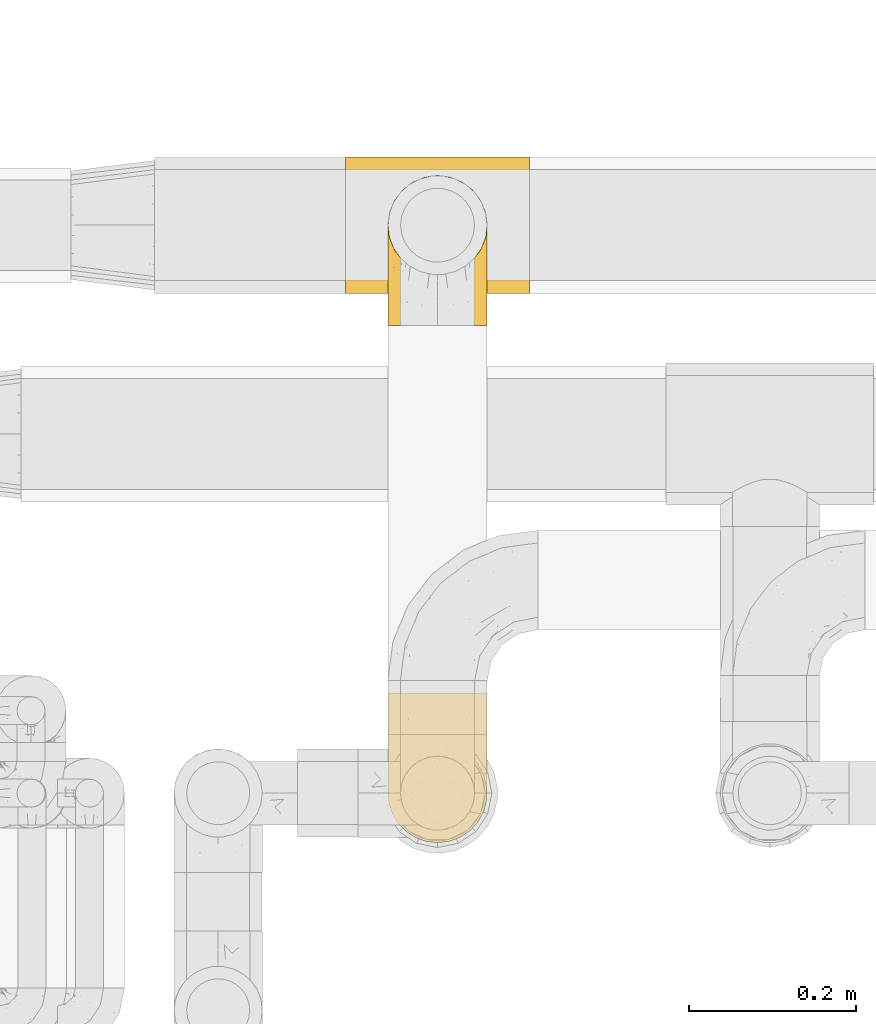
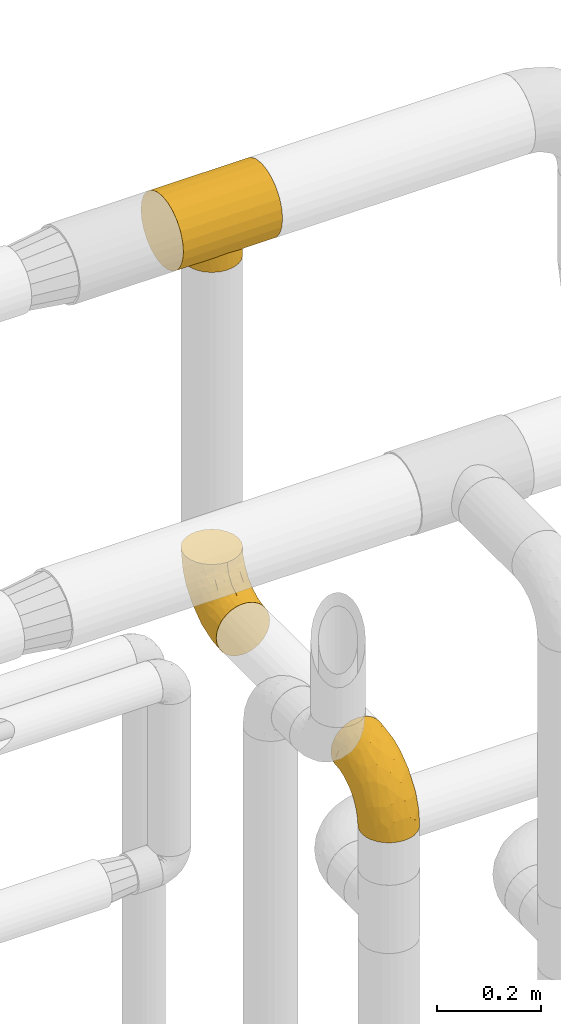
# One storey, part 461 of 827: 3 coverings.
"""IFC2X3 building model written with IfcOpenShell, lengths in millimetres."""

import ifcopenshell
import ifcopenshell.guid

model = None  # the IFC model being written
_history = None  # IfcOwnerHistory: only IFC2X3 demands one
_inside = {}  # id of a spatial element -> (the spatial element, [elements in it])
_under = {}  # id of a project, library or spatial element -> (it, [spatial elements below it])
_declared = {}  # id of a project -> (the project, [libraries it declares])
_typed = {}  # id of a type object -> (the type object, [elements of that type])
_made_of = {}  # id of a material, layer set ... -> (it, [elements and type objects made of it])


def new_model(schema):
    """Start an empty IFC model of exactly this schema.

    Asked for "IFC4X3", IfcOpenShell would pick the latest addendum, in which some entities
    have other attributes; the version numbers below select the first issue.
    IFC2X3 requires an IfcOwnerHistory on every rooted entity: one is made here for all.
    """
    global model, _history
    if schema == "IFC4X3":
        model = ifcopenshell.file(schema_version=(4, 3, 0, 0))
    else:
        model = ifcopenshell.file(schema=schema)
    _inside.clear()
    _under.clear()
    _declared.clear()
    _typed.clear()
    _made_of.clear()
    _history = None
    if model.schema == "IFC2X3":
        org = make("IfcOrganization", Name="unknown")
        user = make(
            "IfcPersonAndOrganization",
            ThePerson=make("IfcPerson", FamilyName="unknown"),
            TheOrganization=org,
        )
        app = make(
            "IfcApplication",
            ApplicationDeveloper=org,
            Version="unknown",
            ApplicationFullName="unknown",
            ApplicationIdentifier="unknown",
        )
        _history = make(
            "IfcOwnerHistory",
            OwningUser=user,
            OwningApplication=app,
            ChangeAction="ADDED",
            CreationDate=0,
        )
    return model


def make(cls, **values):
    """One entity of the class cls with the attributes given. An attribute that is None is left unset."""
    return model.create_entity(
        cls, **{name: value for name, value in values.items() if value is not None}
    )


def entity(cls, *values):
    """Any entity or typed value of the class cls, its attributes in the order of the schema. None: left unset."""
    e = model.create_entity(cls)
    for i, value in enumerate(values):
        if value is not None:
            e[i] = value
    return e


def rooted(cls, **values):
    """An entity with a GlobalId (a new one), such as an element, a storey or a relation."""
    return make(cls, GlobalId=ifcopenshell.guid.new(), OwnerHistory=_history, **values)


def si_unit(unit_type, name, prefix=None):
    """IfcSIUnit, for example si_unit("LENGTHUNIT", "METRE", prefix="MILLI")."""
    return make("IfcSIUnit", UnitType=unit_type, Prefix=prefix, Name=name)


def converted_unit(unit_type, name, factor, base, dimensions=None, offset=None):
    """IfcConversionBasedUnit, such as the inch: factor (a typed value) times the base unit."""
    return make(
        "IfcConversionBasedUnit"
        if offset is None
        else "IfcConversionBasedUnitWithOffset",
        ConversionOffset=offset,
        Dimensions=None
        if dimensions is None
        else entity("IfcDimensionalExponents", *dimensions),
        UnitType=unit_type,
        Name=name,
        ConversionFactor=make(
            "IfcMeasureWithUnit", ValueComponent=factor, UnitComponent=base
        ),
    )


def derived_unit(unit_type, elements):
    """IfcDerivedUnit: a product of units, each with its exponent."""
    return make(
        "IfcDerivedUnit",
        Elements=[
            make("IfcDerivedUnitElement", Unit=unit, Exponent=power)
            for unit, power in elements
        ],
        UnitType=unit_type,
    )


def assignment(units):
    """IfcUnitAssignment: the units of a project."""
    return None if units is None else make("IfcUnitAssignment", Units=units)


def point(xyz):
    """IfcCartesianPoint."""
    return None if xyz is None else make("IfcCartesianPoint", Coordinates=xyz)


def direction(xyz):
    """IfcDirection."""
    return None if xyz is None else make("IfcDirection", DirectionRatios=xyz)


def frame(location, z_axis=None, x_axis=None):
    """IfcAxis2Placement3D, a coordinate frame: its origin and axes. An axis left out is left unset."""
    return make(
        "IfcAxis2Placement3D",
        Location=point(location),
        Axis=direction(z_axis),
        RefDirection=direction(x_axis),
    )


def origin():
    """The frame at (0, 0, 0) with its axes left unset."""
    return frame((0.0, 0.0, 0.0))


def place(relative_to, where):
    """IfcLocalPlacement: puts the frame where relative to a parent placement (None: the world)."""
    return make(
        "IfcLocalPlacement", PlacementRelTo=relative_to, RelativePlacement=where
    )


def context(
    kind, dimensions, precision=None, world=None, true_north=None, identifier=None
):
    """IfcGeometricRepresentationContext, for example the 3D "Model" context."""
    return make(
        "IfcGeometricRepresentationContext",
        ContextIdentifier=identifier,
        ContextType=kind,
        CoordinateSpaceDimension=dimensions,
        Precision=precision,
        WorldCoordinateSystem=world,
        TrueNorth=true_north,
    )


def subcontext(parent, identifier, kind, view, scale=None):
    """IfcGeometricRepresentationSubContext, for example "Body" below "Model"."""
    return make(
        "IfcGeometricRepresentationSubContext",
        ContextIdentifier=identifier,
        ContextType=kind,
        ParentContext=parent,
        TargetScale=scale,
        TargetView=view,
    )


def project(units=None, contexts=None):
    """IfcProject with its units and contexts."""
    return rooted(
        "IfcProject",
        Name="project",
        RepresentationContexts=contexts,
        UnitsInContext=assignment(units),
    )


def spatial(cls, under=None, at=None, **own):
    """A site, building, storey or space (cls), placed at a placement, below another one or the project."""
    s = rooted(cls, ObjectPlacement=at, **own)
    if under is not None:
        _under.setdefault(under.id(), (under, []))[1].append(s)
    return s


def faces_of(points, faces, orient=None, outer=None):
    """IfcFace entities. A face is a list of loops; a loop is a list of indices into points, from 0.

    orient and outer hold one flag for each loop. By default every Orientation is true, the
    first loop of a face is its IfcFaceOuterBound and the others are IfcFaceBound.
    """
    made = []
    for i, loops in enumerate(faces):
        bounds = []
        for j, loop in enumerate(loops):
            is_outer = j == 0 if outer is None else outer[i][j]
            bounds.append(
                make(
                    "IfcFaceOuterBound" if is_outer else "IfcFaceBound",
                    Bound=make("IfcPolyLoop", Polygon=[points[k] for k in loop]),
                    Orientation=True if orient is None else orient[i][j],
                )
            )
        made.append(make("IfcFace", Bounds=bounds))
    return made


def faceted_brep(points, faces, orient=None, outer=None, voids=None):
    """IfcFacetedBrep: a solid bounded by flat faces; with voids (closed shells), ...WithVoids."""
    shared = [point(p) for p in points]
    hull = make("IfcClosedShell", CfsFaces=faces_of(shared, faces, orient, outer))
    if voids is None:
        return make("IfcFacetedBrep", Outer=hull)
    return make(
        "IfcFacetedBrepWithVoids",
        Outer=hull,
        Voids=[
            make(cls, CfsFaces=faces_of(shared, fs, o, b)) for cls, fs, o, b in voids
        ],
    )


def shape(context_of_items, identifier, shape_type, items):
    """IfcShapeRepresentation: the items that make up one representation, for example the "Body"."""
    return make(
        "IfcShapeRepresentation",
        ContextOfItems=context_of_items,
        RepresentationIdentifier=identifier,
        RepresentationType=shape_type,
        Items=items,
    )


def made_of(thing, what):
    """Note that an element or type object is made of a material, layer set ...; save() writes the relation."""
    if what is not None:
        _made_of.setdefault(what.id(), (what, []))[1].append(thing)
    return thing


def element(
    cls,
    number,
    at=None,
    inside=None,
    cuts=None,
    type_object=None,
    material=None,
    context=None,
    identifier="Body",
    shape_type=None,
    held_by="IfcProductDefinitionShape",
    body=None,
    shapes=None,
    **own,
):
    """One element of the class cls, such as IfcWall. Its Tag is "e" and its number.

    at: its placement. inside: the storey or other place that contains it. cuts: it is an
    opening in that element (IfcRelVoidsElement). A single representation is given by context,
    identifier, shape_type and body (its items); several are given by shapes. held_by: the class
    of the entity that holds the representations. save() writes the other relations.
    """
    e = rooted(cls, Tag="e%d" % number, ObjectPlacement=at, **own)
    if body is not None:
        shapes = [shape(context, identifier, shape_type, body)]
    if shapes is not None:
        e.Representation = make(held_by, Representations=shapes)
    if inside is not None:
        _inside.setdefault(inside.id(), (inside, []))[1].append(e)
    if cuts is not None:
        rooted(
            "IfcRelVoidsElement", RelatingBuildingElement=cuts, RelatedOpeningElement=e
        )
    if type_object is not None:
        _typed.setdefault(type_object.id(), (type_object, []))[1].append(e)
    return made_of(e, material)


def aggregate(whole, parts):
    """IfcRelAggregates: a whole, such as a stair, and the parts it consists of."""
    return rooted("IfcRelAggregates", RelatingObject=whole, RelatedObjects=parts)


def save(model, path):
    """Write the relations noted so far, then the file.

    IfcRelAggregates (storeys below a building ...), IfcRelContainedInSpatialStructure (elements
    in a storey), IfcRelDefinesByType, IfcRelAssociatesMaterial and IfcRelDeclares: one each for
    every whole, place, type object, material and project.
    """
    for whole, parts in _under.values():
        aggregate(whole, parts)
    for where, things in _inside.values():
        rooted(
            "IfcRelContainedInSpatialStructure",
            RelatedElements=things,
            RelatingStructure=where,
        )
    for kind, things in _typed.values():
        rooted("IfcRelDefinesByType", RelatedObjects=things, RelatingType=kind)
    for what, things in _made_of.values():
        rooted("IfcRelAssociatesMaterial", RelatedObjects=things, RelatingMaterial=what)
    for by, libraries in _declared.values():
        rooted("IfcRelDeclares", RelatingContext=by, RelatedDefinitions=libraries)
    model.write(path)


model = new_model("IFC2X3")

# Units and contexts
model_context = context("Model", 3, precision=0.01, world=origin(), true_north=direction((6.12303176911189e-17, 1.0)))
body_context = subcontext(model_context, "Body", "Model", "MODEL_VIEW")
ifc_project = project(units=[si_unit("LENGTHUNIT", "METRE", prefix="MILLI"), si_unit("AREAUNIT", "SQUARE_METRE"), si_unit("VOLUMEUNIT", "CUBIC_METRE"), converted_unit("PLANEANGLEUNIT", "DEGREE", entity("IfcRatioMeasure", 0.0174532925199433), si_unit("PLANEANGLEUNIT", "RADIAN"), dimensions=[0, 0, 0, 0, 0, 0, 0]), si_unit("MASSUNIT", "GRAM", prefix="KILO"), derived_unit("MASSDENSITYUNIT", [(si_unit("MASSUNIT", "GRAM", prefix="KILO"), 1), (si_unit("LENGTHUNIT", "METRE"), -3)]), derived_unit("MOMENTOFINERTIAUNIT", [(si_unit("LENGTHUNIT", "METRE"), 4)]), si_unit("TIMEUNIT", "SECOND"), si_unit("FREQUENCYUNIT", "HERTZ"), si_unit("THERMODYNAMICTEMPERATUREUNIT", "DEGREE_CELSIUS"), derived_unit("THERMALTRANSMITTANCEUNIT", [(si_unit("MASSUNIT", "GRAM", prefix="KILO"), 1), (si_unit("THERMODYNAMICTEMPERATUREUNIT", "KELVIN"), -1), (si_unit("TIMEUNIT", "SECOND"), -3)]), derived_unit("VOLUMETRICFLOWRATEUNIT", [(si_unit("LENGTHUNIT", "METRE"), 3), (si_unit("TIMEUNIT", "SECOND"), -1)]), derived_unit("MASSFLOWRATEUNIT", [(si_unit("MASSUNIT", "GRAM", prefix="KILO"), 1), (si_unit("TIMEUNIT", "SECOND"), -1)]), derived_unit("ROTATIONALFREQUENCYUNIT", [(si_unit("TIMEUNIT", "SECOND"), -1)]), si_unit("ELECTRICCURRENTUNIT", "AMPERE"), si_unit("ELECTRICVOLTAGEUNIT", "VOLT"), si_unit("POWERUNIT", "WATT"), si_unit("FORCEUNIT", "NEWTON", prefix="KILO"), si_unit("ILLUMINANCEUNIT", "LUX"), si_unit("LUMINOUSFLUXUNIT", "LUMEN"), si_unit("LUMINOUSINTENSITYUNIT", "CANDELA"), derived_unit("USERDEFINED", [(si_unit("MASSUNIT", "GRAM", prefix="KILO"), -1), (si_unit("LENGTHUNIT", "METRE"), -2), (si_unit("TIMEUNIT", "SECOND"), 3), (si_unit("LUMINOUSFLUXUNIT", "LUMEN"), 1)]), derived_unit("LINEARVELOCITYUNIT", [(si_unit("LENGTHUNIT", "METRE"), 1), (si_unit("TIMEUNIT", "SECOND"), -1)]), si_unit("PRESSUREUNIT", "PASCAL"), derived_unit("USERDEFINED", [(si_unit("LENGTHUNIT", "METRE"), -2), (si_unit("MASSUNIT", "GRAM", prefix="KILO"), 1), (si_unit("TIMEUNIT", "SECOND"), -2)]), derived_unit("LINEARFORCEUNIT", [(si_unit("MASSUNIT", "GRAM", prefix="KILO"), 1), (si_unit("LENGTHUNIT", "METRE"), 1), (si_unit("TIMEUNIT", "SECOND"), -2), (si_unit("LENGTHUNIT", "METRE"), -1)]), derived_unit("PLANARFORCEUNIT", [(si_unit("MASSUNIT", "GRAM", prefix="KILO"), 1), (si_unit("LENGTHUNIT", "METRE"), 1), (si_unit("TIMEUNIT", "SECOND"), -2), (si_unit("LENGTHUNIT", "METRE"), -2)])], contexts=[model_context])

# Site, building, storey
site_placement = place(None, origin())
site = spatial("IfcSite", under=ifc_project, at=site_placement, CompositionType="ELEMENT")
building_placement = place(site_placement, origin())
building = spatial("IfcBuilding", under=site, at=building_placement, CompositionType="ELEMENT")
storey_placement = place(building_placement, frame((0.0, 0.0, 28200.0)))
storey = spatial("IfcBuildingStorey", under=building, at=storey_placement, Name="08", CompositionType="ELEMENT", Elevation=28200.0)

# Coverings
covering_1_placement = place(storey_placement, frame((56940.07, 18097.0, 3404.74)))
element("IfcCovering", 1, at=covering_1_placement, inside=storey, Name=":ADSK_", ObjectType=":ADSK_", PredefinedType="INSULATION", context=body_context, shape_type="Brep", body=[
    faceted_brep([(220.0, 123.85, 165.58), (220.0, 104.19, 173.72), (220.0, 83.1, 176.5), (220.0, 62.0, 173.72), (220.0, 42.35, 165.58), (220.0, 25.47, 152.63), (220.0, 12.51, 135.75), (220.0, 4.37, 116.09), (220.0, 1.6, 95.0), (220.0, 4.37, 73.91), (220.0, 12.51, 54.25), (220.0, 25.47, 37.37), (220.0, 33.91, 30.89), (220.0, 42.35, 24.42), (220.0, 52.17, 20.35), (220.0, 62.0, 16.28), (220.0, 72.55, 14.89), (220.0, 83.1, 13.5), (220.0, 93.64, 14.89), (220.0, 104.19, 16.28), (220.0, 114.02, 20.35), (220.0, 123.85, 24.42), (220.0, 132.28, 30.89), (220.0, 140.72, 37.37), (220.0, 153.68, 54.25), (220.0, 161.82, 73.91), (220.0, 164.6, 95.0), (220.0, 161.82, 116.09), (220.0, 153.68, 135.75), (220.0, 140.72, 152.63), (0.0, 1.6, 95.0), (0.0, 4.37, 116.09), (0.0, 12.51, 135.75), (0.0, 25.47, 152.63), (0.0, 42.35, 165.58), (0.0, 62.0, 173.72), (0.0, 83.1, 176.5), (0.0, 104.19, 173.72), (0.0, 123.85, 165.58), (0.0, 140.72, 152.63), (0.0, 153.68, 135.75), (0.0, 161.82, 116.09), (0.0, 164.6, 95.0), (0.0, 161.82, 73.91), (0.0, 153.68, 54.25), (0.0, 140.72, 37.37), (0.0, 132.28, 30.89), (0.0, 123.85, 24.42), (0.0, 114.02, 20.35), (0.0, 104.19, 16.28), (0.0, 93.64, 14.89), (0.0, 83.1, 13.5), (0.0, 72.55, 14.89), (0.0, 62.0, 16.28), (0.0, 52.17, 20.35), (0.0, 42.35, 24.42), (0.0, 33.91, 30.89), (0.0, 25.47, 37.37), (0.0, 12.51, 54.25), (0.0, 4.37, 73.91), (86.77, 28.32, 34.66), (68.15, 40.8, 25.33), (164.68, 59.63, 16.95), (159.1, 49.48, 20.75), (97.96, 24.83, 38.02), (76.81, 33.71, 30.16), (110.0, 23.6, 39.3), (122.04, 24.83, 38.02), (133.23, 28.32, 34.66), (169.5, 83.1, 13.5), (168.26, 71.0, 14.4), (143.19, 33.71, 30.16), (151.85, 40.8, 25.33), (60.9, 49.48, 20.75), (51.74, 71.0, 14.4), (55.32, 59.63, 16.95), (50.5, 83.1, 13.5), (51.74, 95.19, 14.4), (60.9, 116.71, 20.75), (55.32, 106.56, 16.95), (68.15, 125.39, 25.33), (168.26, 95.19, 14.4), (164.68, 106.56, 16.95), (159.1, 116.71, 20.75), (151.85, 125.39, 25.33), (86.77, 137.88, 34.66), (76.81, 132.48, 30.16), (97.96, 141.36, 38.02), (110.0, 142.6, 39.3), (133.23, 137.88, 34.66), (143.19, 132.48, 30.16), (122.04, 141.36, 38.02), (94.6, 25.62, 0.0), (80.25, 31.57, 0.0), (67.93, 41.02, 0.0), (58.47, 53.35, 0.0), (52.53, 67.7, 0.0), (50.5, 83.1, 0.0), (52.53, 98.5, 0.0), (58.47, 112.85, 0.0), (67.93, 125.17, 0.0), (80.25, 134.62, 0.0), (94.6, 140.57, 0.0), (110.0, 142.6, 0.0), (125.4, 140.57, 0.0), (139.75, 134.62, 0.0), (152.07, 125.17, 0.0), (161.53, 112.85, 0.0), (167.47, 98.5, 0.0), (169.5, 83.1, 0.0), (167.47, 67.7, 0.0), (161.53, 53.35, 0.0), (152.07, 41.02, 0.0), (139.75, 31.57, 0.0), (125.4, 25.62, 0.0), (110.0, 23.6, 0.0)], [[[0, 1, 2, 3, 4, 5, 6, 7, 8, 9, 10, 11, 12, 13, 14, 15, 16, 17, 18, 19, 20, 21, 22, 23, 24, 25, 26, 27, 28, 29]], [[30, 31, 32, 33, 34, 35, 36, 37, 38, 39, 40, 41, 42, 43, 44, 45, 46, 47, 48, 49, 50, 51, 52, 53, 54, 55, 56, 57, 58, 59]], [[34, 33, 5, 4]], [[2, 36, 35, 3]], [[3, 35, 34, 4]], [[6, 32, 31, 7]], [[7, 31, 30, 8]], [[5, 33, 32, 6]], [[59, 9, 8, 30]], [[58, 10, 9, 59]], [[56, 60, 57]], [[56, 55, 61]], [[62, 14, 63]], [[60, 64, 57]], [[60, 56, 65]], [[58, 57, 66]], [[57, 64, 66]], [[58, 66, 10]], [[66, 11, 10]], [[67, 68, 11]], [[69, 16, 70]], [[68, 12, 11]], [[12, 68, 71]], [[72, 12, 71]], [[67, 11, 66]], [[73, 55, 54]], [[74, 53, 52]], [[54, 75, 73]], [[75, 54, 53]], [[73, 61, 55]], [[61, 65, 56]], [[51, 76, 52]], [[69, 17, 16]], [[74, 52, 76]], [[53, 74, 75]], [[72, 63, 13]], [[14, 62, 15]], [[63, 14, 13]], [[13, 12, 72]], [[16, 15, 70]], [[70, 15, 62]], [[51, 50, 76]], [[17, 69, 18]], [[77, 50, 49]], [[48, 47, 78]], [[79, 49, 48]], [[47, 80, 78]], [[49, 79, 77]], [[81, 18, 69]], [[81, 82, 19]], [[21, 83, 84]], [[20, 82, 83]], [[82, 20, 19]], [[46, 80, 47]], [[46, 85, 86]], [[85, 46, 45]], [[79, 48, 78]], [[87, 85, 45]], [[45, 88, 87]], [[81, 19, 18]], [[24, 44, 43, 25]], [[24, 88, 44]], [[44, 88, 45]], [[43, 42, 26, 25]], [[89, 22, 90]], [[89, 23, 22]], [[76, 50, 77]], [[22, 84, 90]], [[84, 22, 21]], [[89, 91, 23]], [[80, 46, 86]], [[88, 23, 91]], [[88, 24, 23]], [[83, 21, 20]], [[27, 41, 40, 28]], [[28, 40, 39, 29]], [[42, 41, 27, 26]], [[0, 38, 37, 1]], [[1, 37, 36, 2]], [[29, 39, 38, 0]], [[92, 93, 94, 95, 96, 97, 98, 99, 100, 101, 102, 103, 104, 105, 106, 107, 108, 109, 110, 111, 112, 113, 114, 115]], [[74, 97, 96]], [[96, 95, 75]], [[94, 73, 95]], [[74, 76, 97]], [[73, 75, 95]], [[74, 96, 75]], [[94, 61, 73]], [[61, 94, 65]], [[65, 94, 93]], [[60, 93, 92]], [[64, 92, 115]], [[65, 93, 60]], [[64, 60, 92]], [[66, 64, 115]], [[67, 115, 114]], [[114, 113, 68]], [[112, 71, 113]], [[112, 72, 71]], [[66, 115, 67]], [[67, 114, 68]], [[113, 71, 68]], [[63, 112, 111]], [[110, 109, 70]], [[62, 111, 110]], [[62, 63, 111]], [[69, 70, 109]], [[62, 110, 70]], [[112, 63, 72]], [[81, 109, 108]], [[108, 107, 82]], [[106, 83, 107]], [[81, 69, 109]], [[83, 82, 107]], [[81, 108, 82]], [[106, 84, 83]], [[84, 106, 90]], [[90, 106, 105]], [[89, 105, 104]], [[91, 104, 103]], [[90, 105, 89]], [[91, 89, 104]], [[88, 91, 103]], [[87, 103, 102]], [[102, 101, 85]], [[100, 86, 101]], [[100, 80, 86]], [[88, 103, 87]], [[87, 102, 85]], [[101, 86, 85]], [[78, 100, 99]], [[99, 98, 79]], [[97, 77, 98]], [[79, 78, 99]], [[76, 77, 97]], [[79, 98, 77]], [[100, 78, 80]]]),
])
covering_2_placement = place(storey_placement, frame((56988.97, 18058.5, 2538.65)))
element("IfcCovering", 2, at=covering_2_placement, inside=storey, Name=":ADSK_", ObjectType=":ADSK_", PredefinedType="INSULATION", context=body_context, shape_type="Brep", body=[
    faceted_brep([(3.09, 1.6, 47.85), (7.49, 1.6, 35.28), (14.58, 1.6, 23.99), (24.0, 1.6, 14.57), (35.29, 1.6, 7.48), (47.87, 1.6, 3.08), (61.1, 1.6, 1.6), (74.34, 1.6, 3.09), (86.92, 1.6, 7.49), (98.2, 1.6, 14.58), (107.62, 1.6, 24.0), (114.71, 1.6, 35.29), (119.11, 1.6, 47.87), (120.6, 1.6, 61.1), (119.1, 1.6, 74.34), (114.7, 1.6, 86.92), (107.61, 1.6, 98.2), (98.19, 1.6, 107.62), (86.9, 1.6, 114.71), (74.32, 1.6, 119.11), (61.1, 1.6, 120.6), (47.85, 1.6, 119.1), (35.28, 1.6, 114.7), (23.99, 1.6, 107.61), (14.57, 1.6, 98.19), (7.48, 1.6, 86.9), (3.08, 1.6, 74.32), (1.6, 1.6, 61.1), (76.5, 64.12, 181.1), (90.85, 70.07, 181.1), (103.17, 79.52, 181.1), (112.62, 91.85, 181.1), (118.57, 106.2, 181.1), (120.6, 121.6, 181.1), (118.57, 137.0, 181.1), (112.62, 151.35, 181.1), (103.17, 163.67, 181.1), (90.85, 173.12, 181.1), (76.5, 179.07, 181.1), (61.1, 181.1, 181.1), (45.7, 179.07, 181.1), (31.35, 173.12, 181.1), (19.02, 163.67, 181.1), (9.57, 151.35, 181.1), (3.62, 137.0, 181.1), (1.6, 121.6, 181.1), (3.62, 106.2, 181.1), (9.57, 91.85, 181.1), (19.02, 79.52, 181.1), (31.35, 70.07, 181.1), (45.7, 64.12, 181.1), (61.1, 62.1, 181.1), (26.31, 166.85, 149.36), (39.89, 171.8, 137.95), (28.09, 156.7, 112.73), (50.3, 175.89, 142.53), (61.1, 174.98, 134.64), (12.16, 34.39, 30.78), (42.08, 141.86, 74.16), (61.1, 157.05, 91.35), (61.1, 128.52, 54.17), (6.43, 125.77, 109.16), (9.16, 142.49, 132.51), (15.36, 137.62, 100.6), (4.19, 133.72, 143.49), (2.63, 116.57, 118.25), (30.97, 116.34, 53.89), (24.52, 137.54, 84.22), (39.03, 160.1, 106.32), (50.35, 166.8, 113.45), (15.92, 154.26, 137.68), (61.1, 48.05, 7.71), (42.9, 44.99, 9.86), (32.76, 75.77, 25.56), (45.82, 109.34, 40.03), (48.35, 78.35, 20.36), (3.49, 96.98, 85.71), (9.05, 106.86, 75.88), (7.36, 67.36, 51.26), (3.1, 49.85, 56.83), (1.6, 72.13, 84.01), (1.6, 98.68, 110.56), (1.6, 107.2, 127.29), (1.6, 115.72, 144.01), (61.1, 91.35, 25.64), (21.1, 45.24, 22.95), (15.48, 73.45, 40.15), (30.83, 33.95, 12.95), (6.04, 32.97, 42.03), (1.6, 16.23, 63.41), (1.6, 38.68, 66.97), (23.42, 74.48, 31.89), (1.6, 85.4, 97.29), (17.92, 115.39, 67.3), (1.6, 55.4, 75.49), (1.6, 119.28, 166.46), (7.93, 85.98, 141.36), (8.89, 71.16, 121.72), (16.11, 70.35, 138.16), (3.9, 103.0, 159.88), (3.02, 94.6, 128.08), (19.8, 55.86, 126.23), (3.12, 81.81, 110.87), (47.53, 60.95, 162.96), (50.13, 52.54, 146.61), (61.1, 57.49, 157.94), (15.01, 24.83, 102.08), (19.01, 37.73, 112.03), (10.55, 50.74, 107.36), (10.96, 87.65, 162.91), (20.75, 74.24, 157.88), (39.41, 15.74, 118.07), (26.2, 20.12, 111.72), (33.73, 61.93, 151.58), (36.85, 65.86, 167.61), (46.97, 40.95, 132.93), (61.1, 44.38, 138.32), (5.84, 38.05, 90.2), (2.73, 55.63, 87.09), (5.41, 56.15, 98.46), (37.06, 31.75, 122.87), (32.67, 49.11, 132.83), (3.19, 20.72, 76.52), (27.56, 32.8, 117.49), (8.27, 18.32, 90.0), (48.52, 24.08, 123.48), (61.1, 24.75, 125.2), (2.79, 70.12, 97.44), (24.84, 61.67, 139.94), (2.63, 41.55, 79.72), (4.47, 96.92, 145.56), (13.37, 81.07, 152.47), (106.07, 70.33, 138.17), (102.38, 55.85, 126.24), (113.29, 71.15, 121.74), (95.98, 20.12, 111.73), (107.17, 24.84, 102.09), (97.33, 61.65, 139.94), (116.35, 38.08, 90.22), (119.56, 41.53, 79.72), (119.46, 55.63, 87.08), (75.21, 40.93, 132.91), (74.65, 60.95, 162.97), (85.34, 65.86, 167.61), (111.23, 87.65, 162.91), (108.82, 81.07, 152.47), (114.26, 85.98, 141.36), (119.17, 94.6, 128.08), (119.3, 84.2, 112.07), (120.6, 98.68, 110.56), (118.29, 103.0, 159.88), (120.6, 119.28, 166.46), (95.24, 40.95, 121.68), (85.12, 31.73, 122.86), (101.44, 74.24, 157.88), (111.63, 50.74, 107.38), (72.08, 52.54, 146.61), (103.17, 37.73, 112.05), (73.66, 24.06, 123.48), (118.38, 68.67, 101.72), (113.92, 18.33, 90.01), (117.72, 96.92, 145.56), (82.77, 15.72, 118.07), (119.0, 20.72, 76.53), (89.51, 49.08, 132.81), (120.6, 38.68, 66.97), (120.6, 16.23, 63.41), (120.6, 55.4, 75.49), (116.32, 51.76, 97.07), (120.6, 85.4, 97.29), (120.6, 115.72, 144.01), (120.6, 107.2, 127.29), (120.6, 72.13, 84.01), (88.46, 61.93, 151.59), (94.1, 156.7, 112.73), (95.88, 166.85, 149.36), (106.27, 154.26, 137.68), (113.03, 142.49, 132.51), (71.89, 175.89, 142.53), (82.3, 171.8, 137.95), (71.84, 166.8, 113.45), (119.56, 116.57, 118.25), (106.83, 137.62, 100.6), (76.37, 109.34, 40.03), (91.22, 116.34, 53.89), (89.44, 75.76, 25.56), (118.7, 96.98, 85.71), (118.0, 133.72, 143.49), (83.16, 160.1, 106.32), (77.34, 78.71, 21.51), (79.3, 44.98, 9.86), (80.11, 141.86, 74.16), (116.16, 32.97, 42.04), (119.09, 49.86, 56.84), (115.76, 125.77, 109.16), (113.14, 106.86, 75.88), (110.04, 34.39, 30.8), (101.1, 45.23, 22.96), (97.67, 137.54, 84.22), (91.37, 33.95, 12.96), (114.84, 67.37, 51.28), (106.72, 73.45, 40.16), (104.27, 115.39, 67.3), (98.78, 74.47, 31.9)], [[[0, 1, 2, 3, 4, 5, 6, 7, 8, 9, 10, 11, 12, 13, 14, 15, 16, 17, 18, 19, 20, 21, 22, 23, 24, 25, 26, 27]], [[28, 29, 30, 31, 32, 33, 34, 35, 36, 37, 38, 39, 40, 41, 42, 43, 44, 45, 46, 47, 48, 49, 50, 51]], [[52, 53, 54]], [[55, 39, 56]], [[57, 2, 1]], [[58, 59, 60]], [[61, 62, 63]], [[64, 61, 65]], [[58, 66, 67]], [[53, 68, 54]], [[41, 40, 53]], [[53, 69, 68]], [[70, 42, 52]], [[42, 41, 52]], [[71, 5, 72]], [[73, 74, 75]], [[43, 70, 62]], [[45, 44, 64]], [[76, 77, 78]], [[79, 80, 76]], [[65, 81, 82, 83]], [[74, 60, 84]], [[85, 2, 57]], [[85, 57, 86]], [[2, 85, 3]], [[42, 70, 43]], [[5, 4, 72]], [[72, 87, 73]], [[4, 3, 87]], [[5, 71, 6]], [[75, 74, 84]], [[64, 62, 61]], [[79, 78, 88]], [[54, 67, 63]], [[74, 58, 60]], [[65, 76, 81]], [[79, 27, 89, 90]], [[75, 71, 72]], [[85, 86, 91]], [[78, 57, 88]], [[56, 69, 55]], [[76, 78, 79]], [[76, 80, 92, 81]], [[77, 76, 61]], [[69, 56, 59]], [[4, 87, 72]], [[91, 66, 73]], [[58, 74, 66]], [[3, 85, 87]], [[73, 87, 85]], [[88, 57, 1]], [[86, 57, 78]], [[77, 86, 78]], [[93, 66, 91]], [[73, 66, 74]], [[67, 93, 63]], [[1, 0, 88]], [[0, 27, 79]], [[0, 79, 88]], [[79, 90, 94, 80]], [[64, 83, 95, 45]], [[76, 65, 61]], [[83, 64, 65]], [[62, 44, 43]], [[62, 64, 44]], [[63, 62, 70]], [[54, 63, 70]], [[63, 93, 77]], [[63, 77, 61]], [[77, 93, 86]], [[67, 54, 68]], [[66, 93, 67]], [[53, 52, 41]], [[70, 52, 54]], [[58, 69, 59]], [[55, 69, 53]], [[69, 58, 68]], [[67, 68, 58]], [[53, 40, 55]], [[39, 55, 40]], [[71, 75, 84]], [[73, 75, 72]], [[91, 86, 93]], [[73, 85, 91]], [[96, 97, 98]], [[83, 99, 95]], [[82, 81, 100]], [[95, 99, 46]], [[101, 98, 97]], [[47, 46, 99]], [[97, 100, 102]], [[103, 104, 105]], [[106, 107, 108]], [[109, 48, 47]], [[48, 110, 49]], [[108, 101, 97]], [[111, 112, 22]], [[51, 50, 103]], [[113, 103, 114]], [[23, 22, 112]], [[115, 116, 104]], [[108, 117, 106]], [[112, 106, 23]], [[94, 118, 80]], [[108, 119, 117]], [[120, 115, 121]], [[112, 107, 106]], [[25, 122, 26]], [[122, 89, 26]], [[101, 123, 121]], [[109, 110, 48]], [[124, 25, 24]], [[125, 20, 126]], [[120, 111, 125]], [[110, 113, 114]], [[127, 97, 102]], [[106, 24, 23]], [[125, 115, 120]], [[111, 22, 21]], [[126, 115, 125]], [[117, 124, 106]], [[110, 98, 128]], [[117, 129, 124]], [[117, 118, 129]], [[100, 97, 96]], [[124, 122, 25]], [[83, 82, 130]], [[99, 130, 109]], [[100, 81, 102]], [[100, 130, 82]], [[130, 100, 96]], [[81, 92, 102]], [[127, 80, 118]], [[21, 20, 125]], [[111, 120, 123]], [[21, 125, 111]], [[115, 126, 116]], [[104, 116, 105]], [[101, 107, 123]], [[104, 121, 115]], [[128, 121, 113]], [[105, 51, 103]], [[121, 104, 113]], [[114, 103, 50]], [[113, 104, 103]], [[106, 124, 24]], [[94, 129, 118]], [[123, 107, 112]], [[101, 108, 107]], [[99, 109, 47]], [[131, 109, 96]], [[89, 122, 90]], [[89, 27, 26]], [[122, 129, 90]], [[97, 127, 119]], [[119, 127, 118]], [[102, 92, 127]], [[90, 129, 94]], [[80, 127, 92]], [[124, 129, 122]], [[117, 119, 118]], [[97, 119, 108]], [[50, 49, 114]], [[110, 114, 49]], [[109, 130, 96]], [[130, 99, 83]], [[128, 98, 101]], [[98, 110, 131]], [[121, 128, 101]], [[110, 128, 113]], [[46, 45, 95]], [[111, 123, 112]], [[121, 123, 120]], [[98, 131, 96]], [[110, 109, 131]], [[132, 133, 134]], [[135, 17, 136]], [[132, 137, 133]], [[138, 139, 140]], [[126, 141, 116]], [[105, 142, 51]], [[16, 136, 17]], [[142, 143, 28]], [[144, 145, 146]], [[147, 148, 149]], [[31, 150, 32]], [[150, 151, 32]], [[135, 152, 153]], [[30, 29, 154]], [[155, 136, 138]], [[31, 30, 144]], [[156, 116, 141]], [[136, 155, 157]], [[126, 158, 141]], [[159, 148, 134]], [[20, 19, 158]], [[156, 142, 105]], [[160, 136, 16]], [[147, 161, 146]], [[135, 18, 17]], [[18, 162, 19]], [[136, 157, 135]], [[146, 145, 132]], [[160, 163, 139]], [[16, 15, 160]], [[15, 14, 163]], [[164, 141, 153]], [[133, 155, 134]], [[152, 135, 157]], [[165, 163, 166]], [[163, 14, 166]], [[162, 135, 153]], [[29, 143, 154]], [[165, 167, 139]], [[162, 158, 19]], [[159, 134, 155]], [[167, 140, 139]], [[140, 168, 138]], [[159, 169, 148]], [[144, 150, 31]], [[161, 170, 150]], [[171, 170, 161]], [[149, 171, 147]], [[134, 147, 146]], [[134, 148, 147]], [[135, 162, 18]], [[169, 159, 172]], [[169, 149, 148]], [[158, 162, 153]], [[158, 153, 141]], [[158, 126, 20]], [[153, 152, 164]], [[116, 156, 105]], [[137, 164, 133]], [[156, 164, 173]], [[164, 156, 141]], [[142, 28, 51]], [[156, 173, 142]], [[143, 142, 173]], [[163, 160, 15]], [[136, 160, 138]], [[155, 133, 157]], [[133, 164, 152]], [[154, 144, 30]], [[144, 146, 161]], [[14, 13, 166]], [[172, 159, 140]], [[140, 167, 172]], [[168, 159, 155]], [[160, 139, 138]], [[165, 139, 163]], [[154, 143, 173]], [[29, 28, 143]], [[171, 161, 147]], [[144, 161, 150]], [[159, 168, 140]], [[155, 138, 168]], [[146, 132, 134]], [[137, 154, 173]], [[154, 137, 132]], [[164, 137, 173]], [[151, 150, 170]], [[151, 33, 32]], [[133, 152, 157]], [[144, 154, 145]], [[132, 145, 154]], [[174, 175, 176]], [[35, 34, 177]], [[178, 179, 180]], [[181, 170, 171, 149]], [[176, 182, 174]], [[183, 184, 185]], [[186, 149, 169, 172]], [[187, 33, 151, 170]], [[179, 188, 180]], [[34, 187, 177]], [[39, 38, 178]], [[189, 185, 190]], [[184, 183, 191]], [[175, 179, 37]], [[38, 37, 179]], [[35, 176, 36]], [[180, 59, 56]], [[192, 193, 12]], [[37, 36, 175]], [[181, 187, 170]], [[181, 186, 194]], [[176, 177, 182]], [[8, 7, 190]], [[194, 186, 195]], [[13, 12, 193]], [[196, 192, 11]], [[10, 9, 197]], [[60, 183, 84]], [[174, 182, 198]], [[197, 196, 10]], [[193, 172, 167, 165]], [[8, 199, 9]], [[189, 183, 185]], [[60, 59, 191]], [[200, 196, 201]], [[190, 199, 8]], [[7, 6, 71]], [[10, 196, 11]], [[202, 203, 184]], [[199, 185, 197]], [[7, 71, 190]], [[183, 60, 191]], [[189, 71, 84]], [[193, 186, 172]], [[200, 201, 195]], [[180, 191, 59]], [[185, 199, 190]], [[197, 9, 199]], [[201, 196, 197]], [[192, 196, 200]], [[203, 201, 197]], [[195, 201, 202]], [[191, 188, 198]], [[202, 201, 203]], [[193, 192, 200]], [[12, 11, 192]], [[186, 193, 200]], [[193, 165, 166, 13]], [[186, 181, 149]], [[187, 181, 194]], [[187, 194, 177]], [[187, 34, 33]], [[194, 195, 182]], [[35, 177, 176]], [[194, 182, 177]], [[182, 202, 198]], [[200, 195, 186]], [[182, 195, 202]], [[202, 184, 198]], [[191, 198, 184]], [[176, 175, 36]], [[179, 175, 174]], [[178, 180, 56]], [[179, 174, 188]], [[198, 188, 174]], [[191, 180, 188]], [[39, 178, 56]], [[38, 179, 178]], [[71, 189, 190]], [[84, 183, 189]], [[197, 185, 203]], [[184, 203, 185]]]),
])
covering_3_placement = place(storey_placement, frame((56988.97, 17438.9, 2478.15)))
element("IfcCovering", 3, at=covering_3_placement, inside=storey, Name=":ADSK_", ObjectType=":ADSK_", PredefinedType="INSULATION", context=body_context, shape_type="Brep", body=[
    faceted_brep([(119.1, 47.85, 1.6), (114.7, 35.28, 1.6), (107.61, 23.99, 1.6), (98.19, 14.57, 1.6), (86.9, 7.48, 1.6), (74.32, 3.08, 1.6), (61.1, 1.6, 1.6), (47.85, 3.09, 1.6), (35.28, 7.49, 1.6), (23.99, 14.58, 1.6), (14.57, 24.0, 1.6), (7.48, 35.29, 1.6), (3.08, 47.87, 1.6), (1.6, 61.1, 1.6), (3.09, 74.34, 1.6), (7.49, 86.92, 1.6), (14.58, 98.2, 1.6), (24.0, 107.62, 1.6), (35.29, 114.71, 1.6), (47.87, 119.11, 1.6), (61.1, 120.6, 1.6), (74.34, 119.1, 1.6), (86.92, 114.7, 1.6), (98.2, 107.61, 1.6), (107.62, 98.19, 1.6), (114.71, 86.9, 1.6), (119.11, 74.32, 1.6), (120.6, 61.1, 1.6), (45.7, 181.1, 64.12), (31.35, 181.1, 70.07), (19.02, 181.1, 79.52), (9.57, 181.1, 91.85), (3.62, 181.1, 106.2), (1.6, 181.1, 121.6), (3.62, 181.1, 137.0), (9.57, 181.1, 151.35), (19.02, 181.1, 163.67), (31.35, 181.1, 173.12), (45.7, 181.1, 179.07), (61.1, 181.1, 181.1), (76.5, 181.1, 179.07), (90.85, 181.1, 173.12), (103.17, 181.1, 163.67), (112.62, 181.1, 151.35), (118.57, 181.1, 137.0), (120.6, 181.1, 121.6), (118.57, 181.1, 106.2), (112.62, 181.1, 91.85), (103.17, 181.1, 79.52), (90.85, 181.1, 70.07), (76.5, 181.1, 64.12), (61.1, 181.1, 62.1), (95.88, 149.36, 166.85), (82.3, 137.95, 171.8), (94.1, 112.73, 156.7), (71.89, 142.53, 175.89), (61.1, 134.64, 174.98), (110.03, 30.78, 34.39), (80.11, 74.16, 141.86), (61.1, 91.35, 157.05), (61.1, 54.17, 128.52), (115.76, 109.16, 125.77), (113.03, 132.51, 142.49), (106.83, 100.6, 137.62), (118.0, 143.49, 133.72), (119.56, 118.25, 116.57), (91.22, 53.89, 116.34), (97.67, 84.22, 137.54), (83.16, 106.32, 160.1), (71.84, 113.45, 166.8), (106.27, 137.68, 154.26), (61.1, 7.71, 48.05), (79.29, 9.86, 44.99), (89.43, 25.56, 75.77), (76.37, 40.03, 109.34), (73.84, 20.36, 78.35), (118.7, 85.71, 96.98), (113.14, 75.88, 106.86), (114.84, 51.26, 67.36), (119.09, 56.83, 49.85), (120.6, 84.01, 72.13), (120.6, 110.56, 98.68), (120.6, 127.29, 107.2), (120.6, 144.01, 115.72), (61.1, 25.64, 91.35), (101.09, 22.95, 45.24), (106.71, 40.15, 73.45), (91.36, 12.95, 33.95), (116.15, 42.03, 32.97), (120.6, 63.41, 16.23), (120.6, 66.97, 38.68), (98.77, 31.89, 74.48), (120.6, 97.29, 85.4), (104.27, 67.3, 115.39), (120.6, 75.49, 55.4), (120.6, 166.46, 119.28), (114.26, 141.36, 85.98), (113.3, 121.72, 71.16), (106.08, 138.16, 70.35), (118.29, 159.88, 103.0), (119.17, 128.08, 94.6), (102.39, 126.23, 55.86), (119.07, 110.87, 81.81), (74.66, 162.96, 60.95), (72.06, 146.61, 52.54), (61.1, 157.94, 57.49), (107.18, 102.08, 24.83), (103.18, 112.03, 37.73), (111.64, 107.36, 50.74), (111.23, 162.91, 87.65), (101.44, 157.88, 74.24), (82.78, 118.07, 15.74), (95.99, 111.72, 20.12), (88.46, 151.58, 61.93), (85.34, 167.61, 65.86), (75.22, 132.93, 40.95), (61.1, 138.32, 44.38), (116.35, 90.2, 38.05), (119.46, 87.09, 55.63), (116.78, 98.46, 56.15), (85.13, 122.87, 31.75), (89.52, 132.83, 49.11), (119.0, 76.52, 20.72), (94.63, 117.49, 32.8), (113.92, 90.0, 18.32), (73.67, 123.48, 24.08), (61.1, 125.2, 24.75), (119.4, 97.44, 70.12), (97.35, 139.94, 61.67), (119.56, 79.72, 41.55), (117.72, 145.56, 96.92), (108.82, 152.47, 81.07), (16.12, 138.17, 70.33), (19.81, 126.24, 55.85), (8.9, 121.74, 71.15), (26.21, 111.73, 20.12), (15.02, 102.09, 24.84), (24.86, 139.94, 61.65), (5.84, 90.22, 38.08), (2.63, 79.72, 41.53), (2.73, 87.08, 55.63), (46.99, 132.91, 40.93), (47.54, 162.97, 60.95), (36.85, 167.61, 65.86), (10.96, 162.91, 87.65), (13.37, 152.47, 81.07), (7.93, 141.36, 85.98), (3.02, 128.08, 94.6), (2.89, 112.07, 84.2), (1.6, 110.56, 98.68), (3.9, 159.88, 103.0), (1.6, 166.46, 119.28), (26.96, 121.68, 40.95), (37.08, 122.86, 31.73), (20.75, 157.88, 74.24), (10.56, 107.38, 50.74), (50.11, 146.61, 52.54), (19.02, 112.05, 37.73), (48.54, 123.48, 24.06), (3.81, 101.72, 68.67), (8.27, 90.01, 18.33), (4.47, 145.56, 96.92), (39.43, 118.07, 15.72), (3.19, 76.53, 20.72), (32.68, 132.81, 49.08), (1.6, 66.97, 38.68), (1.6, 63.41, 16.23), (1.6, 75.49, 55.4), (5.87, 97.07, 51.76), (1.6, 97.29, 85.4), (1.6, 144.01, 115.72), (1.6, 127.29, 107.2), (1.6, 84.01, 72.13), (33.73, 151.59, 61.93), (28.09, 112.73, 156.7), (26.31, 149.36, 166.85), (15.92, 137.68, 154.26), (9.16, 132.51, 142.49), (50.3, 142.53, 175.89), (39.89, 137.95, 171.8), (50.35, 113.45, 166.8), (2.63, 118.25, 116.57), (15.36, 100.6, 137.62), (45.82, 40.03, 109.34), (30.97, 53.89, 116.34), (32.75, 25.56, 75.76), (3.49, 85.71, 96.98), (4.19, 143.49, 133.72), (39.03, 106.32, 160.1), (44.85, 21.51, 78.71), (42.89, 9.86, 44.98), (42.08, 74.16, 141.86), (6.03, 42.04, 32.97), (3.1, 56.84, 49.86), (6.43, 109.16, 125.77), (9.05, 75.88, 106.86), (12.15, 30.8, 34.39), (21.09, 22.96, 45.23), (24.52, 84.22, 137.54), (30.82, 12.96, 33.95), (7.35, 51.28, 67.37), (15.47, 40.16, 73.45), (17.92, 67.3, 115.39), (23.41, 31.9, 74.47)], [[[0, 1, 2, 3, 4, 5, 6, 7, 8, 9, 10, 11, 12, 13, 14, 15, 16, 17, 18, 19, 20, 21, 22, 23, 24, 25, 26, 27]], [[28, 29, 30, 31, 32, 33, 34, 35, 36, 37, 38, 39, 40, 41, 42, 43, 44, 45, 46, 47, 48, 49, 50, 51]], [[52, 53, 54]], [[55, 39, 56]], [[57, 2, 1]], [[58, 59, 60]], [[61, 62, 63]], [[64, 61, 65]], [[58, 66, 67]], [[53, 68, 54]], [[41, 40, 53]], [[53, 69, 68]], [[70, 42, 52]], [[42, 41, 52]], [[71, 5, 72]], [[73, 74, 75]], [[43, 70, 62]], [[45, 44, 64]], [[76, 77, 78]], [[79, 80, 76]], [[65, 81, 82, 83]], [[74, 60, 84]], [[85, 2, 57]], [[85, 57, 86]], [[2, 85, 3]], [[42, 70, 43]], [[5, 4, 72]], [[72, 87, 73]], [[4, 3, 87]], [[5, 71, 6]], [[75, 74, 84]], [[64, 62, 61]], [[79, 78, 88]], [[54, 67, 63]], [[74, 58, 60]], [[65, 76, 81]], [[79, 27, 89, 90]], [[75, 71, 72]], [[85, 86, 91]], [[78, 57, 88]], [[56, 69, 55]], [[76, 78, 79]], [[76, 80, 92, 81]], [[77, 76, 61]], [[69, 56, 59]], [[4, 87, 72]], [[91, 66, 73]], [[58, 74, 66]], [[3, 85, 87]], [[73, 87, 85]], [[88, 57, 1]], [[86, 57, 78]], [[77, 86, 78]], [[93, 66, 91]], [[73, 66, 74]], [[67, 93, 63]], [[1, 0, 88]], [[0, 27, 79]], [[0, 79, 88]], [[79, 90, 94, 80]], [[64, 83, 95, 45]], [[76, 65, 61]], [[83, 64, 65]], [[62, 44, 43]], [[62, 64, 44]], [[63, 62, 70]], [[54, 63, 70]], [[63, 93, 77]], [[63, 77, 61]], [[77, 93, 86]], [[67, 54, 68]], [[66, 93, 67]], [[53, 52, 41]], [[70, 52, 54]], [[58, 69, 59]], [[55, 69, 53]], [[69, 58, 68]], [[67, 68, 58]], [[53, 40, 55]], [[39, 55, 40]], [[71, 75, 84]], [[73, 75, 72]], [[91, 86, 93]], [[73, 85, 91]], [[96, 97, 98]], [[83, 99, 95]], [[82, 81, 100]], [[95, 99, 46]], [[101, 98, 97]], [[47, 46, 99]], [[97, 100, 102]], [[103, 104, 105]], [[106, 107, 108]], [[109, 48, 47]], [[48, 110, 49]], [[108, 101, 97]], [[111, 112, 22]], [[51, 50, 103]], [[113, 103, 114]], [[23, 22, 112]], [[115, 116, 104]], [[108, 117, 106]], [[112, 106, 23]], [[94, 118, 80]], [[108, 119, 117]], [[120, 115, 121]], [[112, 107, 106]], [[25, 122, 26]], [[122, 89, 26]], [[101, 123, 121]], [[109, 110, 48]], [[124, 25, 24]], [[125, 20, 126]], [[120, 111, 125]], [[110, 113, 114]], [[127, 97, 102]], [[106, 24, 23]], [[125, 115, 120]], [[111, 22, 21]], [[126, 115, 125]], [[117, 124, 106]], [[110, 98, 128]], [[117, 129, 124]], [[117, 118, 129]], [[100, 97, 96]], [[124, 122, 25]], [[83, 82, 130]], [[99, 130, 109]], [[100, 81, 102]], [[100, 130, 82]], [[130, 100, 96]], [[81, 92, 102]], [[127, 80, 118]], [[21, 20, 125]], [[111, 120, 123]], [[21, 125, 111]], [[115, 126, 116]], [[104, 116, 105]], [[101, 107, 123]], [[104, 121, 115]], [[128, 121, 113]], [[105, 51, 103]], [[121, 104, 113]], [[114, 103, 50]], [[113, 104, 103]], [[106, 124, 24]], [[94, 129, 118]], [[123, 107, 112]], [[101, 108, 107]], [[99, 109, 47]], [[131, 109, 96]], [[89, 122, 90]], [[89, 27, 26]], [[122, 129, 90]], [[97, 127, 119]], [[119, 127, 118]], [[102, 92, 127]], [[90, 129, 94]], [[80, 127, 92]], [[124, 129, 122]], [[117, 119, 118]], [[97, 119, 108]], [[50, 49, 114]], [[110, 114, 49]], [[109, 130, 96]], [[130, 99, 83]], [[128, 98, 101]], [[98, 110, 131]], [[121, 128, 101]], [[110, 128, 113]], [[46, 45, 95]], [[111, 123, 112]], [[121, 123, 120]], [[98, 131, 96]], [[110, 109, 131]], [[132, 133, 134]], [[135, 17, 136]], [[132, 137, 133]], [[138, 139, 140]], [[126, 141, 116]], [[105, 142, 51]], [[16, 136, 17]], [[142, 143, 28]], [[144, 145, 146]], [[147, 148, 149]], [[31, 150, 32]], [[150, 151, 32]], [[135, 152, 153]], [[30, 29, 154]], [[155, 136, 138]], [[31, 30, 144]], [[156, 116, 141]], [[136, 155, 157]], [[126, 158, 141]], [[159, 148, 134]], [[20, 19, 158]], [[156, 142, 105]], [[160, 136, 16]], [[147, 161, 146]], [[135, 18, 17]], [[18, 162, 19]], [[136, 157, 135]], [[146, 145, 132]], [[160, 163, 139]], [[16, 15, 160]], [[15, 14, 163]], [[164, 141, 153]], [[133, 155, 134]], [[152, 135, 157]], [[165, 163, 166]], [[163, 14, 166]], [[162, 135, 153]], [[29, 143, 154]], [[165, 167, 139]], [[162, 158, 19]], [[159, 134, 155]], [[167, 140, 139]], [[140, 168, 138]], [[159, 169, 148]], [[144, 150, 31]], [[161, 170, 150]], [[171, 170, 161]], [[149, 171, 147]], [[134, 147, 146]], [[134, 148, 147]], [[135, 162, 18]], [[169, 159, 172]], [[169, 149, 148]], [[158, 162, 153]], [[158, 153, 141]], [[158, 126, 20]], [[153, 152, 164]], [[116, 156, 105]], [[137, 164, 133]], [[156, 164, 173]], [[164, 156, 141]], [[142, 28, 51]], [[156, 173, 142]], [[143, 142, 173]], [[163, 160, 15]], [[136, 160, 138]], [[155, 133, 157]], [[133, 164, 152]], [[154, 144, 30]], [[144, 146, 161]], [[14, 13, 166]], [[172, 159, 140]], [[140, 167, 172]], [[168, 159, 155]], [[160, 139, 138]], [[165, 139, 163]], [[154, 143, 173]], [[29, 28, 143]], [[171, 161, 147]], [[144, 161, 150]], [[159, 168, 140]], [[155, 138, 168]], [[146, 132, 134]], [[137, 154, 173]], [[154, 137, 132]], [[164, 137, 173]], [[151, 150, 170]], [[151, 33, 32]], [[133, 152, 157]], [[144, 154, 145]], [[132, 145, 154]], [[174, 175, 176]], [[35, 34, 177]], [[178, 179, 180]], [[181, 170, 171, 149]], [[176, 182, 174]], [[183, 184, 185]], [[186, 149, 169, 172]], [[187, 33, 151, 170]], [[179, 188, 180]], [[34, 187, 177]], [[39, 38, 178]], [[189, 185, 190]], [[184, 183, 191]], [[175, 179, 37]], [[38, 37, 179]], [[35, 176, 36]], [[180, 59, 56]], [[192, 193, 12]], [[37, 36, 175]], [[181, 187, 170]], [[181, 186, 194]], [[176, 177, 182]], [[8, 7, 190]], [[194, 186, 195]], [[13, 12, 193]], [[196, 192, 11]], [[10, 9, 197]], [[60, 183, 84]], [[174, 182, 198]], [[197, 196, 10]], [[193, 172, 167, 165]], [[8, 199, 9]], [[189, 183, 185]], [[60, 59, 191]], [[200, 196, 201]], [[190, 199, 8]], [[7, 6, 71]], [[10, 196, 11]], [[202, 203, 184]], [[199, 185, 197]], [[7, 71, 190]], [[183, 60, 191]], [[189, 71, 84]], [[193, 186, 172]], [[200, 201, 195]], [[180, 191, 59]], [[185, 199, 190]], [[197, 9, 199]], [[201, 196, 197]], [[192, 196, 200]], [[203, 201, 197]], [[195, 201, 202]], [[191, 188, 198]], [[202, 201, 203]], [[193, 192, 200]], [[12, 11, 192]], [[186, 193, 200]], [[193, 165, 166, 13]], [[186, 181, 149]], [[187, 181, 194]], [[187, 194, 177]], [[187, 34, 33]], [[194, 195, 182]], [[35, 177, 176]], [[194, 182, 177]], [[182, 202, 198]], [[200, 195, 186]], [[182, 195, 202]], [[202, 184, 198]], [[191, 198, 184]], [[176, 175, 36]], [[179, 175, 174]], [[178, 180, 56]], [[179, 174, 188]], [[198, 188, 174]], [[191, 180, 188]], [[39, 178, 56]], [[38, 179, 178]], [[71, 189, 190]], [[84, 183, 189]], [[197, 185, 203]], [[184, 203, 185]]]),
])

save(model, "model.ifc")
